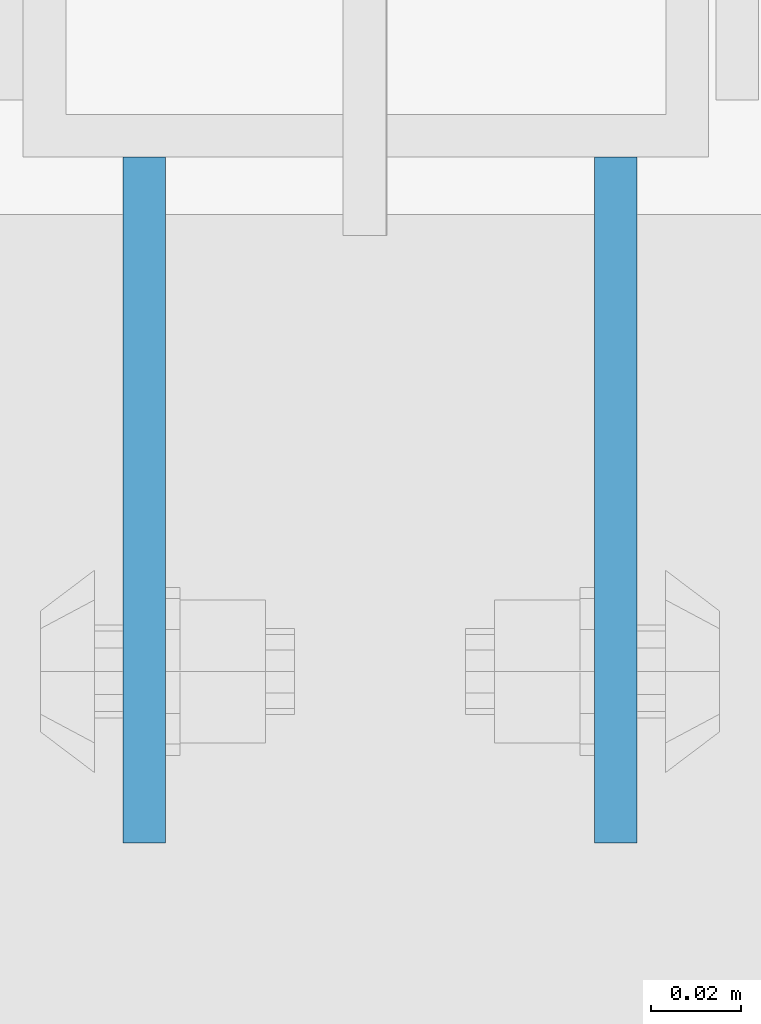
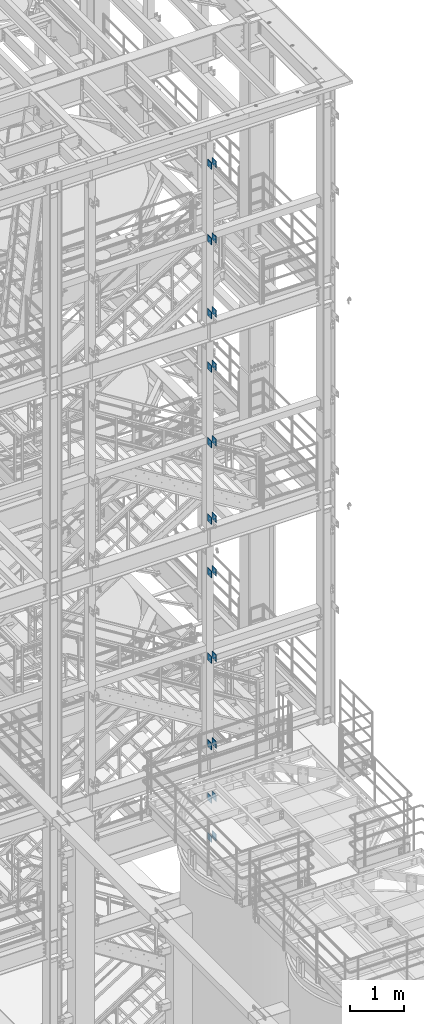
# One storey, part 1146 of 1876: 22 beams, 4 elements without a shape of their own.
"""IFC2X3 building model written with IfcOpenShell, lengths in millimetres."""

from ifc_helpers import new_model, si_unit, frame, origin_with_axes, place, context, subcontext, project, spatial, faceted_brep, material, type_object, element, aggregate, save


model = new_model("IFC2X3")

# Units and contexts
model_context = context("Model", 3, precision=1e-05, world=origin_with_axes())
body_context = subcontext(model_context, "Body", "Model", "MODEL_VIEW")
ifc_project = project(units=[si_unit("LENGTHUNIT", "METRE", prefix="MILLI"), si_unit("AREAUNIT", "SQUARE_METRE"), si_unit("VOLUMEUNIT", "CUBIC_METRE"), si_unit("MASSUNIT", "GRAM", prefix="KILO"), si_unit("TIMEUNIT", "SECOND"), si_unit("PLANEANGLEUNIT", "RADIAN"), si_unit("SOLIDANGLEUNIT", "STERADIAN"), si_unit("THERMODYNAMICTEMPERATUREUNIT", "DEGREE_CELSIUS"), si_unit("LUMINOUSINTENSITYUNIT", "LUMEN")], contexts=[model_context])

# Site, building, storey
site_placement = place(None, origin_with_axes())
site = spatial("IfcSite", under=ifc_project, at=site_placement, CompositionType="ELEMENT")
building_placement = place(site_placement, origin_with_axes())
building = spatial("IfcBuilding", under=site, at=building_placement, Name="Undefined", CompositionType="ELEMENT")
storey_placement = place(building_placement, origin_with_axes())
storey = spatial("IfcBuildingStorey", under=building, at=storey_placement, Name="Undefined", CompositionType="ELEMENT", Elevation=0.0)

# Assembly, beams
assembly_1_placement = place(storey_placement, origin_with_axes())
assembly_1 = element("IfcElementAssembly", 1, at=assembly_1_placement, inside=storey, Name="FRAME", AssemblyPlace="NOTDEFINED", PredefinedType="RIGID_FRAME")
ifc_material = material(Name="STEEL/A36")
beam_type = type_object("IfcBeamType", PredefinedType="NOTDEFINED")
beam_1_placement = place(assembly_1_placement, frame((5030.7762944527, -7188.2, 6330.95), z_axis=(0.0, 0.0, -1.0), x_axis=(0.0, -1.0, 0.0)))
beam_1 = element("IfcBeam", 2, at=beam_1_placement, type_object=beam_type, material=ifc_material, Name="PLATE", context=body_context, shape_type="Brep", body=[
    faceted_brep([(0.0, 4.76249999999982, -76.1999999999998), (3.63797880709171e-12, 4.76249999999982, 76.1999969482422), (152.399993896484, 4.76250000000073, 76.1999969482422), (152.4, 4.76249999999982, -76.1999999999998), (3.63797880709171e-12, -4.76249999999982, 76.1999969482422), (152.399993896484, -4.76250000000073, 76.1999969482422), (0.0, -4.76249999999982, -76.1999999999998), (152.4, -4.76249999999982, -76.1999999999998)], [[[0, 1, 2, 3]], [[4, 5, 2, 1]], [[4, 6, 7, 5]], [[6, 0, 3, 7]], [[5, 7, 3, 2]], [[6, 4, 1, 0]]]),
])
beam_2_placement = place(assembly_1_placement, frame((5135.55129445271, -7188.2, 6330.95), z_axis=(0.0, 0.0, -1.0), x_axis=(0.0, -1.0, 0.0)))
beam_2 = element("IfcBeam", 3, at=beam_2_placement, type_object=beam_type, material=ifc_material, Name="PLATE", context=body_context, shape_type="Brep", body=[
    faceted_brep([(0.0, 4.76249999999982, -76.1999999999998), (3.63797880709171e-12, 4.76249999999982, 76.1999969482422), (152.399993896484, 4.76250000000073, 76.1999969482422), (152.4, 4.76249999999982, -76.1999999999998), (3.63797880709171e-12, -4.76249999999982, 76.1999969482422), (152.399993896484, -4.76250000000073, 76.1999969482422), (0.0, -4.76249999999982, -76.1999999999998), (152.4, -4.76249999999982, -76.1999999999998)], [[[0, 1, 2, 3]], [[4, 5, 2, 1]], [[4, 6, 7, 5]], [[6, 0, 3, 7]], [[5, 7, 3, 2]], [[6, 4, 1, 0]]]),
])
beam_3_placement = place(assembly_1_placement, frame((5030.7762944527, -7188.2, 7226.3), z_axis=(0.0, 0.0, -1.0), x_axis=(0.0, -1.0, 0.0)))
beam_3 = element("IfcBeam", 4, at=beam_3_placement, type_object=beam_type, material=ifc_material, Name="PLATE", context=body_context, shape_type="Brep", body=[
    faceted_brep([(0.0, 4.76249999999982, -76.1999999999998), (3.63797880709171e-12, 4.76249999999982, 76.1999969482422), (152.399993896484, 4.76250000000073, 76.1999969482422), (152.4, 4.76249999999982, -76.1999999999998), (3.63797880709171e-12, -4.76249999999982, 76.1999969482422), (152.399993896484, -4.76250000000073, 76.1999969482422), (0.0, -4.76249999999982, -76.1999999999998), (152.4, -4.76249999999982, -76.1999999999998)], [[[0, 1, 2, 3]], [[4, 5, 2, 1]], [[4, 6, 7, 5]], [[6, 0, 3, 7]], [[5, 7, 3, 2]], [[6, 4, 1, 0]]]),
])
beam_4_placement = place(assembly_1_placement, frame((5135.55129445271, -7188.2, 7226.3), z_axis=(0.0, 0.0, -1.0), x_axis=(0.0, -1.0, 0.0)))
beam_4 = element("IfcBeam", 5, at=beam_4_placement, type_object=beam_type, material=ifc_material, Name="PLATE", context=body_context, shape_type="Brep", body=[
    faceted_brep([(0.0, 4.76249999999982, -76.1999999999998), (3.63797880709171e-12, 4.76249999999982, 76.1999969482422), (152.399993896484, 4.76250000000073, 76.1999969482422), (152.4, 4.76249999999982, -76.1999999999998), (3.63797880709171e-12, -4.76249999999982, 76.1999969482422), (152.399993896484, -4.76250000000073, 76.1999969482422), (0.0, -4.76249999999982, -76.1999999999998), (152.4, -4.76249999999982, -76.1999999999998)], [[[0, 1, 2, 3]], [[4, 5, 2, 1]], [[4, 6, 7, 5]], [[6, 0, 3, 7]], [[5, 7, 3, 2]], [[6, 4, 1, 0]]]),
])
aggregate(assembly_1, [beam_1, beam_2, beam_3, beam_4])

assembly_2_placement = place(storey_placement, origin_with_axes())
assembly_2 = element("IfcElementAssembly", 6, at=assembly_2_placement, inside=storey, Name="FRAME", AssemblyPlace="NOTDEFINED", PredefinedType="RIGID_FRAME")
beam_5_placement = place(assembly_2_placement, frame((5030.7762944527, -7188.2, 8445.5), z_axis=(0.0, 0.0, -1.0), x_axis=(0.0, -1.0, 0.0)))
beam_5 = element("IfcBeam", 7, at=beam_5_placement, type_object=beam_type, material=ifc_material, Name="PLATE", context=body_context, shape_type="Brep", body=[
    faceted_brep([(0.0, 4.76249999999982, -76.1999999999998), (3.63797880709171e-12, 4.76249999999982, 76.1999969482422), (152.399993896484, 4.76250000000073, 76.1999969482422), (152.4, 4.76249999999982, -76.1999999999998), (3.63797880709171e-12, -4.76249999999982, 76.1999969482422), (152.399993896484, -4.76250000000073, 76.1999969482422), (0.0, -4.76249999999982, -76.1999999999998), (152.4, -4.76249999999982, -76.1999999999998)], [[[0, 1, 2, 3]], [[4, 5, 2, 1]], [[4, 6, 7, 5]], [[6, 0, 3, 7]], [[5, 7, 3, 2]], [[6, 4, 1, 0]]]),
])
beam_6_placement = place(assembly_2_placement, frame((5135.5512944527, -7188.2, 8445.5), z_axis=(0.0, 0.0, -1.0), x_axis=(0.0, -1.0, 0.0)))
beam_6 = element("IfcBeam", 8, at=beam_6_placement, type_object=beam_type, material=ifc_material, Name="PLATE", context=body_context, shape_type="Brep", body=[
    faceted_brep([(0.0, 4.76249999999982, -76.1999999999998), (3.63797880709171e-12, 4.76249999999982, 76.1999969482422), (152.399993896484, 4.76250000000073, 76.1999969482422), (152.4, 4.76249999999982, -76.1999999999998), (3.63797880709171e-12, -4.76249999999982, 76.1999969482422), (152.399993896484, -4.76250000000073, 76.1999969482422), (0.0, -4.76249999999982, -76.1999999999998), (152.4, -4.76249999999982, -76.1999999999998)], [[[0, 1, 2, 3]], [[4, 5, 2, 1]], [[4, 6, 7, 5]], [[6, 0, 3, 7]], [[5, 7, 3, 2]], [[6, 4, 1, 0]]]),
])
beam_7_placement = place(assembly_2_placement, frame((5030.7762944527, -7188.2, 10420.35), z_axis=(0.0, 0.0, -1.0), x_axis=(0.0, -1.0, 0.0)))
beam_7 = element("IfcBeam", 9, at=beam_7_placement, type_object=beam_type, material=ifc_material, Name="PLATE", context=body_context, shape_type="Brep", body=[
    faceted_brep([(0.0, 4.76249999999982, -76.1999999999998), (3.63797880709171e-12, 4.76249999999982, 76.1999969482422), (152.399993896484, 4.76250000000073, 76.1999969482422), (152.4, 4.76249999999982, -76.1999999999998), (3.63797880709171e-12, -4.76249999999982, 76.1999969482422), (152.399993896484, -4.76250000000073, 76.1999969482422), (0.0, -4.76249999999982, -76.1999999999998), (152.4, -4.76249999999982, -76.1999999999998)], [[[0, 1, 2, 3]], [[4, 5, 2, 1]], [[4, 6, 7, 5]], [[6, 0, 3, 7]], [[5, 7, 3, 2]], [[6, 4, 1, 0]]]),
])
beam_8_placement = place(assembly_2_placement, frame((5135.5512944527, -7188.2, 10420.35), z_axis=(0.0, 0.0, -1.0), x_axis=(0.0, -1.0, 0.0)))
beam_8 = element("IfcBeam", 10, at=beam_8_placement, type_object=beam_type, material=ifc_material, Name="PLATE", context=body_context, shape_type="Brep", body=[
    faceted_brep([(0.0, 4.76249999999982, -76.1999999999998), (3.63797880709171e-12, 4.76249999999982, 76.1999969482422), (152.399993896484, 4.76250000000073, 76.1999969482422), (152.4, 4.76249999999982, -76.1999999999998), (3.63797880709171e-12, -4.76249999999982, 76.1999969482422), (152.399993896484, -4.76250000000073, 76.1999969482422), (0.0, -4.76249999999982, -76.1999999999998), (152.4, -4.76249999999982, -76.1999999999998)], [[[0, 1, 2, 3]], [[4, 5, 2, 1]], [[4, 6, 7, 5]], [[6, 0, 3, 7]], [[5, 7, 3, 2]], [[6, 4, 1, 0]]]),
])
beam_9_placement = place(assembly_2_placement, frame((5030.7762944527, -7188.2, 12369.8), z_axis=(0.0, 0.0, -1.0), x_axis=(0.0, -1.0, 0.0)))
beam_9 = element("IfcBeam", 11, at=beam_9_placement, type_object=beam_type, material=ifc_material, Name="PLATE", context=body_context, shape_type="Brep", body=[
    faceted_brep([(0.0, 4.76249999999982, -76.1999999999998), (3.63797880709171e-12, 4.76249999999982, 76.1999969482422), (152.399993896484, 4.76250000000073, 76.1999969482422), (152.4, 4.76249999999982, -76.1999999999998), (3.63797880709171e-12, -4.76249999999982, 76.1999969482422), (152.399993896484, -4.76250000000073, 76.1999969482422), (0.0, -4.76249999999982, -76.1999999999998), (152.4, -4.76249999999982, -76.1999999999998)], [[[0, 1, 2, 3]], [[4, 5, 2, 1]], [[4, 6, 7, 5]], [[6, 0, 3, 7]], [[5, 7, 3, 2]], [[6, 4, 1, 0]]]),
])
beam_10_placement = place(assembly_2_placement, frame((5135.5512944527, -7188.2, 12369.8), z_axis=(0.0, 0.0, -1.0), x_axis=(0.0, -1.0, 0.0)))
beam_10 = element("IfcBeam", 12, at=beam_10_placement, type_object=beam_type, material=ifc_material, Name="PLATE", context=body_context, shape_type="Brep", body=[
    faceted_brep([(0.0, 4.76249999999982, -76.1999999999998), (3.63797880709171e-12, 4.76249999999982, 76.1999969482422), (152.399993896484, 4.76250000000073, 76.1999969482422), (152.4, 4.76249999999982, -76.1999999999998), (3.63797880709171e-12, -4.76249999999982, 76.1999969482422), (152.399993896484, -4.76250000000073, 76.1999969482422), (0.0, -4.76249999999982, -76.1999999999998), (152.4, -4.76249999999982, -76.1999999999998)], [[[0, 1, 2, 3]], [[4, 5, 2, 1]], [[4, 6, 7, 5]], [[6, 0, 3, 7]], [[5, 7, 3, 2]], [[6, 4, 1, 0]]]),
])
aggregate(assembly_2, [beam_5, beam_6, beam_7, beam_8, beam_9, beam_10])

assembly_3_placement = place(storey_placement, origin_with_axes())
assembly_3 = element("IfcElementAssembly", 13, at=assembly_3_placement, inside=storey, Name="FRAME", AssemblyPlace="NOTDEFINED", PredefinedType="RIGID_FRAME")
beam_11_placement = place(assembly_3_placement, frame((5030.7762944527, -7188.2, 13589.0), z_axis=(0.0, 0.0, -1.0), x_axis=(0.0, -1.0, 0.0)))
beam_11 = element("IfcBeam", 14, at=beam_11_placement, type_object=beam_type, material=ifc_material, Name="PLATE", context=body_context, shape_type="Brep", body=[
    faceted_brep([(0.0, 4.76249999999982, -76.1999999999998), (3.63797880709171e-12, 4.76249999999982, 76.1999969482422), (152.399993896484, 4.76250000000073, 76.1999969482422), (152.4, 4.76249999999982, -76.1999999999998), (3.63797880709171e-12, -4.76249999999982, 76.1999969482422), (152.399993896484, -4.76250000000073, 76.1999969482422), (0.0, -4.76249999999982, -76.1999999999998), (152.4, -4.76249999999982, -76.1999999999998)], [[[0, 1, 2, 3]], [[4, 5, 2, 1]], [[4, 6, 7, 5]], [[6, 0, 3, 7]], [[5, 7, 3, 2]], [[6, 4, 1, 0]]]),
])
beam_12_placement = place(assembly_3_placement, frame((5135.5512944527, -7188.2, 13589.0), z_axis=(0.0, 0.0, -1.0), x_axis=(0.0, -1.0, 0.0)))
beam_12 = element("IfcBeam", 15, at=beam_12_placement, type_object=beam_type, material=ifc_material, Name="PLATE", context=body_context, shape_type="Brep", body=[
    faceted_brep([(0.0, 4.76249999999982, -76.1999999999998), (3.63797880709171e-12, 4.76249999999982, 76.1999969482422), (152.399993896484, 4.76250000000073, 76.1999969482422), (152.4, 4.76249999999982, -76.1999999999998), (3.63797880709171e-12, -4.76249999999982, 76.1999969482422), (152.399993896484, -4.76250000000073, 76.1999969482422), (0.0, -4.76249999999982, -76.1999999999998), (152.4, -4.76249999999982, -76.1999999999998)], [[[0, 1, 2, 3]], [[4, 5, 2, 1]], [[4, 6, 7, 5]], [[6, 0, 3, 7]], [[5, 7, 3, 2]], [[6, 4, 1, 0]]]),
])
beam_13_placement = place(assembly_3_placement, frame((5030.7762944527, -7188.2, 15335.25), z_axis=(0.0, 0.0, -1.0), x_axis=(0.0, -1.0, 0.0)))
beam_13 = element("IfcBeam", 16, at=beam_13_placement, type_object=beam_type, material=ifc_material, Name="PLATE", context=body_context, shape_type="Brep", body=[
    faceted_brep([(0.0, 4.76249999999982, -76.1999999999998), (3.63797880709171e-12, 4.76249999999982, 76.1999969482422), (152.399993896484, 4.76250000000073, 76.1999969482422), (152.4, 4.76249999999982, -76.1999999999998), (3.63797880709171e-12, -4.76249999999982, 76.1999969482422), (152.399993896484, -4.76250000000073, 76.1999969482422), (0.0, -4.76249999999982, -76.1999999999998), (152.4, -4.76249999999982, -76.1999999999998)], [[[0, 1, 2, 3]], [[4, 5, 2, 1]], [[4, 6, 7, 5]], [[6, 0, 3, 7]], [[5, 7, 3, 2]], [[6, 4, 1, 0]]]),
])
beam_14_placement = place(assembly_3_placement, frame((5135.5512944527, -7188.2, 15335.25), z_axis=(0.0, 0.0, -1.0), x_axis=(0.0, -1.0, 0.0)))
beam_14 = element("IfcBeam", 17, at=beam_14_placement, type_object=beam_type, material=ifc_material, Name="PLATE", context=body_context, shape_type="Brep", body=[
    faceted_brep([(0.0, 4.76249999999982, -76.1999999999998), (3.63797880709171e-12, 4.76249999999982, 76.1999969482422), (152.399993896484, 4.76250000000073, 76.1999969482422), (152.4, 4.76249999999982, -76.1999999999998), (3.63797880709171e-12, -4.76249999999982, 76.1999969482422), (152.399993896484, -4.76250000000073, 76.1999969482422), (0.0, -4.76249999999982, -76.1999999999998), (152.4, -4.76249999999982, -76.1999999999998)], [[[0, 1, 2, 3]], [[4, 5, 2, 1]], [[4, 6, 7, 5]], [[6, 0, 3, 7]], [[5, 7, 3, 2]], [[6, 4, 1, 0]]]),
])
beam_15_placement = place(assembly_3_placement, frame((5030.7762944527, -7188.2, 17056.1), z_axis=(0.0, 0.0, -1.0), x_axis=(0.0, -1.0, 0.0)))
beam_15 = element("IfcBeam", 18, at=beam_15_placement, type_object=beam_type, material=ifc_material, Name="PLATE", context=body_context, shape_type="Brep", body=[
    faceted_brep([(0.0, 4.76249999999982, -76.1999999999998), (3.63797880709171e-12, 4.76249999999982, 76.1999969482422), (152.399993896484, 4.76250000000073, 76.1999969482422), (152.4, 4.76249999999982, -76.1999999999998), (3.63797880709171e-12, -4.76249999999982, 76.1999969482422), (152.399993896484, -4.76250000000073, 76.1999969482422), (0.0, -4.76249999999982, -76.1999999999998), (152.4, -4.76249999999982, -76.1999999999998)], [[[0, 1, 2, 3]], [[4, 5, 2, 1]], [[4, 6, 7, 5]], [[6, 0, 3, 7]], [[5, 7, 3, 2]], [[6, 4, 1, 0]]]),
])
beam_16_placement = place(assembly_3_placement, frame((5135.5512944527, -7188.2, 17056.1), z_axis=(0.0, 0.0, -1.0), x_axis=(0.0, -1.0, 0.0)))
beam_16 = element("IfcBeam", 19, at=beam_16_placement, type_object=beam_type, material=ifc_material, Name="PLATE", context=body_context, shape_type="Brep", body=[
    faceted_brep([(0.0, 4.76249999999982, -76.1999999999998), (3.63797880709171e-12, 4.76249999999982, 76.1999969482422), (152.399993896484, 4.76250000000073, 76.1999969482422), (152.4, 4.76249999999982, -76.1999999999998), (3.63797880709171e-12, -4.76249999999982, 76.1999969482422), (152.399993896484, -4.76250000000073, 76.1999969482422), (0.0, -4.76249999999982, -76.1999999999998), (152.4, -4.76249999999982, -76.1999999999998)], [[[0, 1, 2, 3]], [[4, 5, 2, 1]], [[4, 6, 7, 5]], [[6, 0, 3, 7]], [[5, 7, 3, 2]], [[6, 4, 1, 0]]]),
])
aggregate(assembly_3, [beam_11, beam_12, beam_13, beam_14, beam_15, beam_16])

assembly_4_placement = place(storey_placement, origin_with_axes())
assembly_4 = element("IfcElementAssembly", 20, at=assembly_4_placement, inside=storey, Name="FRAME", AssemblyPlace="NOTDEFINED", PredefinedType="RIGID_FRAME")
beam_17_placement = place(assembly_4_placement, frame((5030.7762944527, -7188.2, 18275.3), z_axis=(0.0, 0.0, -1.0), x_axis=(0.0, -1.0, 0.0)))
beam_17 = element("IfcBeam", 21, at=beam_17_placement, type_object=beam_type, material=ifc_material, Name="PLATE", context=body_context, shape_type="Brep", body=[
    faceted_brep([(0.0, 4.76249999999982, -76.1999999999998), (3.63797880709171e-12, 4.76249999999982, 76.1999969482422), (152.399993896484, 4.76250000000073, 76.1999969482422), (152.4, 4.76249999999982, -76.1999999999998), (3.63797880709171e-12, -4.76249999999982, 76.1999969482422), (152.399993896484, -4.76250000000073, 76.1999969482422), (0.0, -4.76249999999982, -76.1999999999998), (152.4, -4.76249999999982, -76.1999999999998)], [[[0, 1, 2, 3]], [[4, 5, 2, 1]], [[4, 6, 7, 5]], [[6, 0, 3, 7]], [[5, 7, 3, 2]], [[6, 4, 1, 0]]]),
])
beam_18_placement = place(assembly_4_placement, frame((5135.5512944527, -7188.2, 18275.3), z_axis=(0.0, 0.0, -1.0), x_axis=(0.0, -1.0, 0.0)))
beam_18 = element("IfcBeam", 22, at=beam_18_placement, type_object=beam_type, material=ifc_material, Name="PLATE", context=body_context, shape_type="Brep", body=[
    faceted_brep([(0.0, 4.76249999999982, -76.1999999999998), (3.63797880709171e-12, 4.76249999999982, 76.1999969482422), (152.399993896484, 4.76250000000073, 76.1999969482422), (152.4, 4.76249999999982, -76.1999999999998), (3.63797880709171e-12, -4.76249999999982, 76.1999969482422), (152.399993896484, -4.76250000000073, 76.1999969482422), (0.0, -4.76249999999982, -76.1999999999998), (152.4, -4.76249999999982, -76.1999999999998)], [[[0, 1, 2, 3]], [[4, 5, 2, 1]], [[4, 6, 7, 5]], [[6, 0, 3, 7]], [[5, 7, 3, 2]], [[6, 4, 1, 0]]]),
])
beam_19_placement = place(assembly_4_placement, frame((5030.7762944527, -7188.2, 19958.05), z_axis=(0.0, 0.0, -1.0), x_axis=(0.0, -1.0, 0.0)))
beam_19 = element("IfcBeam", 23, at=beam_19_placement, type_object=beam_type, material=ifc_material, Name="PLATE", context=body_context, shape_type="Brep", body=[
    faceted_brep([(0.0, 4.76249999999982, -76.1999999999998), (3.63797880709171e-12, 4.76249999999982, 76.1999969482422), (152.399993896484, 4.76250000000073, 76.1999969482422), (152.4, 4.76249999999982, -76.1999999999998), (3.63797880709171e-12, -4.76249999999982, 76.1999969482422), (152.399993896484, -4.76250000000073, 76.1999969482422), (0.0, -4.76249999999982, -76.1999999999998), (152.4, -4.76249999999982, -76.1999999999998)], [[[0, 1, 2, 3]], [[4, 5, 2, 1]], [[4, 6, 7, 5]], [[6, 0, 3, 7]], [[5, 7, 3, 2]], [[6, 4, 1, 0]]]),
])
beam_20_placement = place(assembly_4_placement, frame((5135.5512944527, -7188.2, 19958.05), z_axis=(0.0, 0.0, -1.0), x_axis=(0.0, -1.0, 0.0)))
beam_20 = element("IfcBeam", 24, at=beam_20_placement, type_object=beam_type, material=ifc_material, Name="PLATE", context=body_context, shape_type="Brep", body=[
    faceted_brep([(0.0, 4.76249999999982, -76.1999999999998), (3.63797880709171e-12, 4.76249999999982, 76.1999969482422), (152.399993896484, 4.76250000000073, 76.1999969482422), (152.4, 4.76249999999982, -76.1999999999998), (3.63797880709171e-12, -4.76249999999982, 76.1999969482422), (152.399993896484, -4.76250000000073, 76.1999969482422), (0.0, -4.76249999999982, -76.1999999999998), (152.4, -4.76249999999982, -76.1999999999998)], [[[0, 1, 2, 3]], [[4, 5, 2, 1]], [[4, 6, 7, 5]], [[6, 0, 3, 7]], [[5, 7, 3, 2]], [[6, 4, 1, 0]]]),
])
beam_21_placement = place(assembly_4_placement, frame((5030.7762944527, -7188.2, 21678.9), z_axis=(0.0, 0.0, -1.0), x_axis=(0.0, -1.0, 0.0)))
beam_21 = element("IfcBeam", 25, at=beam_21_placement, type_object=beam_type, material=ifc_material, Name="PLATE", context=body_context, shape_type="Brep", body=[
    faceted_brep([(0.0, 4.76249999999982, -76.1999999999998), (3.63797880709171e-12, 4.76249999999982, 76.1999969482422), (152.399993896484, 4.76250000000073, 76.1999969482422), (152.4, 4.76249999999982, -76.1999999999998), (3.63797880709171e-12, -4.76249999999982, 76.1999969482422), (152.399993896484, -4.76250000000073, 76.1999969482422), (0.0, -4.76249999999982, -76.1999999999998), (152.4, -4.76249999999982, -76.1999999999998)], [[[0, 1, 2, 3]], [[4, 5, 2, 1]], [[4, 6, 7, 5]], [[6, 0, 3, 7]], [[5, 7, 3, 2]], [[6, 4, 1, 0]]]),
])
beam_22_placement = place(assembly_4_placement, frame((5135.5512944527, -7188.2, 21678.9), z_axis=(0.0, 0.0, -1.0), x_axis=(0.0, -1.0, 0.0)))
beam_22 = element("IfcBeam", 26, at=beam_22_placement, type_object=beam_type, material=ifc_material, Name="PLATE", context=body_context, shape_type="Brep", body=[
    faceted_brep([(0.0, 4.76249999999982, -76.1999999999998), (3.63797880709171e-12, 4.76249999999982, 76.1999969482422), (152.399993896484, 4.76250000000073, 76.1999969482422), (152.4, 4.76249999999982, -76.1999999999998), (3.63797880709171e-12, -4.76249999999982, 76.1999969482422), (152.399993896484, -4.76250000000073, 76.1999969482422), (0.0, -4.76249999999982, -76.1999999999998), (152.4, -4.76249999999982, -76.1999999999998)], [[[0, 1, 2, 3]], [[4, 5, 2, 1]], [[4, 6, 7, 5]], [[6, 0, 3, 7]], [[5, 7, 3, 2]], [[6, 4, 1, 0]]]),
])
aggregate(assembly_4, [beam_17, beam_18, beam_19, beam_20, beam_21, beam_22])

save(model, "model.ifc")
